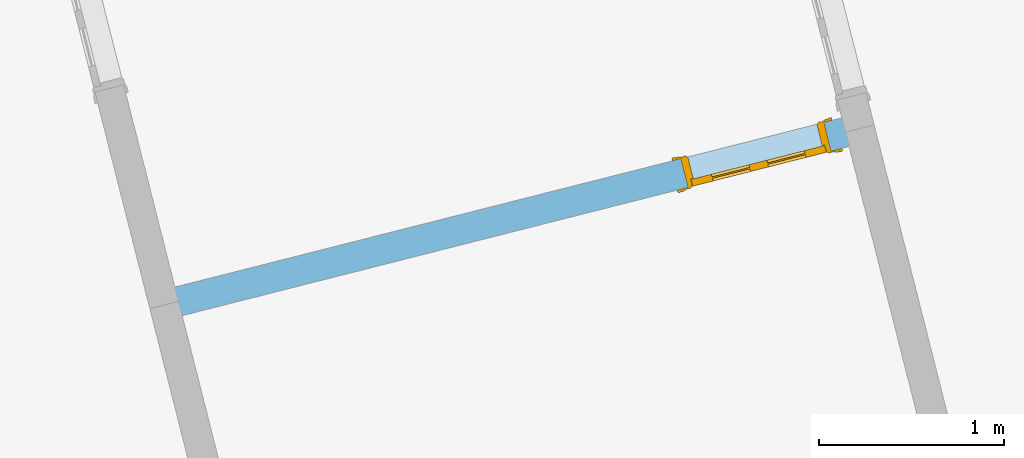
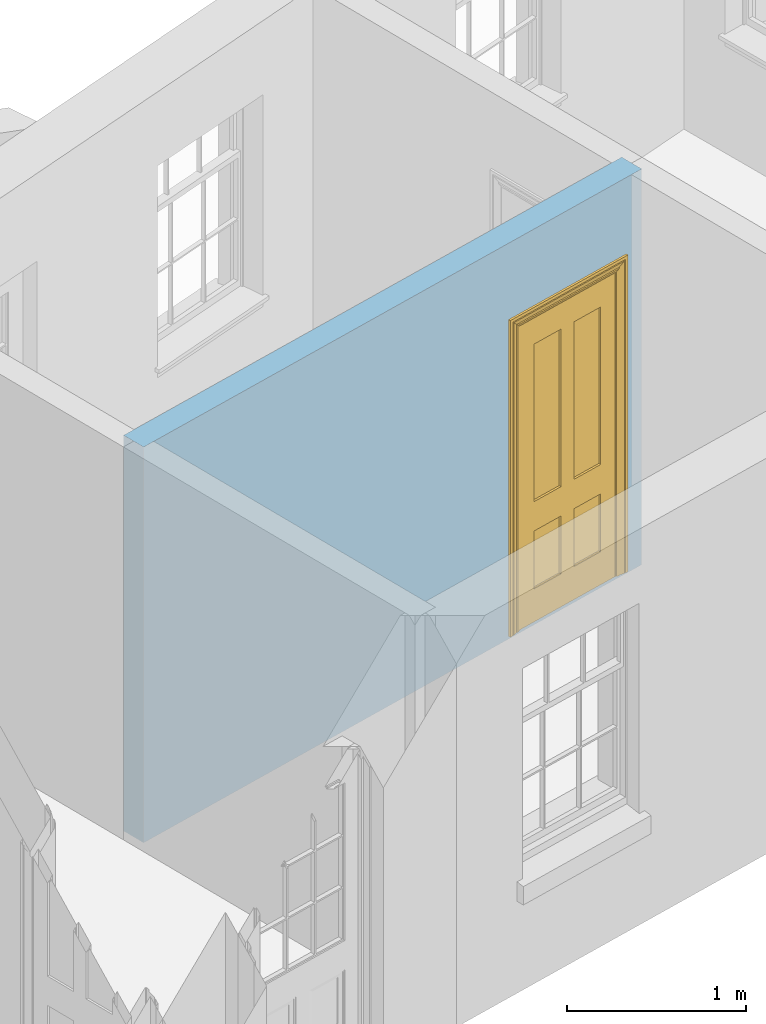
# One storey, part 8 of 15: 1 door, 1 opening, plus 1 element that does not belong to this part.
"""IFC2X3 building model written with IfcOpenShell, lengths in metres."""

from ifc_helpers import new_model, si_unit, frame, origin, place, context, subcontext, project, spatial, polyline, outline, extrude, faceted_brep, material, layer, layer_set, layer_usage, element, fill, save


model = new_model("IFC2X3")

# Units and contexts
model_context = context("Model", 3, world=origin())
body_context = subcontext(model_context, "Body", "Model", "MODEL_VIEW")
ifc_project = project(units=[si_unit("PLANEANGLEUNIT", "RADIAN"), si_unit("MASSUNIT", "GRAM", prefix="KILO"), si_unit("FORCEUNIT", "NEWTON", prefix="KILO"), si_unit("LENGTHUNIT", "METRE")], contexts=[model_context])

# Site, building, storey
site_placement = place(None, origin())
site = spatial("IfcSite", under=ifc_project, at=site_placement, CompositionType="ELEMENT")
building_placement = place(None, origin())
building = spatial("IfcBuilding", under=site, at=building_placement, Name="Building plot-13", CompositionType="ELEMENT")
storey_placement = place(None, frame((0.0, 0.0, 4.0)))
storey = spatial("IfcBuildingStorey", under=building, at=storey_placement, Name="Floor 0", CompositionType="ELEMENT", Elevation=4.0)

# Wall, opening, door
ifc_material = material(Name="Masonry")
ifc_layer = layer(ifc_material, 0.16, ventilated=False)
ifc_layer_set = layer_set([ifc_layer], Name="My Wall")
ifc_layer_usage = layer_usage(ifc_layer_set, "AXIS2", "NEGATIVE", 0.08)
wall_placement = place(storey_placement, origin())
wall = element("IfcWallStandardCase", 1, at=wall_placement, inside=storey, material=ifc_layer_usage, Name="interior", context=body_context, shape_type="SweptSolid", body=[
    extrude(outline(polyline([(76.3872594352377, 48.5815460629626), (76.3479245240301, 48.736635600844), (72.5821025731174, 47.7815210645155), (72.621437484325, 47.6264315266341), (76.3872594352377, 48.5815460629626)])), origin(), (0.0, 0.0, 1.0), 2.7),
])
opening_placement = place(storey_placement, frame((0.0, 0.0, 0.0199999999999996)))
opening = element("IfcOpeningElement", 2, at=opening_placement, cuts=wall, Name="Opening", ObjectType="Opening", context=body_context, shape_type="SweptSolid", body=[
    extrude(outline(polyline([(76.1734487939134, 48.6923838257354), (75.3980011045061, 48.495709269697), (75.4373360157138, 48.3406197318156), (76.2127837051211, 48.5372942878539), (76.1734487939134, 48.6923838257354)])), origin(), (0.0, 0.0, 1.0), 2.1),
])
door_placement = place(storey_placement, frame((76.1931162495173, 48.6148390567947, 0.0199999999999996), z_axis=(0.0, 0.0, 1.0), x_axis=(-0.775447689407301, -0.19667455603836, 0.0)))
door = element("IfcDoor", 3, at=door_placement, inside=storey, Name="toilet inside door", OverallHeight=2.1, OverallWidth=0.8, context=body_context, shape_type="Brep", held_by="IfcProductRepresentation", body=[
    faceted_brep([(0.773, 0.08, 1.895), (0.66, 0.08, 1.895), (0.66, 0.08, 2.073), (0.773, 0.08, 2.073), (0.773, 0.08, 0.82), (0.66, 0.08, 0.82), (0.45, 0.08, 1.895), (0.45, 0.08, 2.073), (0.773, 0.08, 0.62), (0.66, 0.08, 0.62), (0.66, 0.065, 0.82), (0.66, 0.065, 1.895), (0.45, 0.065, 1.895), (0.35, 0.08, 1.895), (0.35, 0.08, 2.073), (0.773, 0.08, 0.225), (0.66, 0.08, 0.225), (0.45, 0.08, 0.62), (0.45, 0.08, 0.82), (0.45, 0.065, 0.82), (0.35, 0.08, 0.82), (0.14, 0.08, 2.073), (0.14, 0.08, 1.895), (0.773, 0.08, 0.0), (0.66, 0.08, 0.0), (0.66, 0.065, 0.225), (0.66, 0.065, 0.62), (0.45, 0.065, 0.62), (0.35, 0.08, 0.62), (0.35, 0.065, 0.82), (0.35, 0.065, 1.895), (0.14, 0.065, 1.895), (0.027, 0.08, 2.073), (0.027, 0.08, 1.895), (0.773, 0.042, 0.0), (0.66, 0.042, 0.0), (0.45, 0.08, 0.0), (0.45, 0.08, 0.225), (0.45, 0.065, 0.225), (0.35, 0.08, 0.225), (0.14, 0.08, 0.82), (0.14, 0.08, 0.62), (0.14, 0.065, 0.82), (0.027, 0.08, 0.82), (0.773, 0.042, 0.225), (0.66, 0.042, 0.225), (0.45, 0.042, 0.0), (0.35, 0.08, 0.0), (0.35, 0.065, 0.225), (0.35, 0.065, 0.62), (0.14, 0.065, 0.62), (0.027, 0.08, 0.62), (0.773, 0.042, 0.62), (0.66, 0.042, 0.62), (0.45, 0.042, 0.225), (0.35, 0.042, 0.0), (0.14, 0.08, 0.225), (0.14, 0.08, 0.0), (0.14, 0.065, 0.225), (0.027, 0.08, 0.225), (0.773, 0.042, 0.82), (0.66, 0.042, 0.82), (0.66, 0.057, 0.62), (0.66, 0.057, 0.225), (0.45, 0.057, 0.225), (0.35, 0.042, 0.225), (0.14, 0.042, 0.0), (0.027, 0.08, 0.0), (0.773, 0.042, 1.895), (0.66, 0.042, 1.895), (0.45, 0.042, 0.62), (0.45, 0.042, 0.82), (0.45, 0.057, 0.62), (0.35, 0.042, 0.62), (0.14, 0.042, 0.225), (0.027, 0.042, 0.0), (0.773, 0.042, 2.073), (0.66, 0.042, 2.073), (0.66, 0.057, 1.895), (0.66, 0.057, 0.82), (0.45, 0.057, 0.82), (0.35, 0.042, 0.82), (0.35, 0.057, 0.62), (0.35, 0.057, 0.225), (0.14, 0.057, 0.225), (0.027, 0.042, 0.225), (0.45, 0.042, 1.895), (0.45, 0.042, 2.073), (0.45, 0.057, 1.895), (0.35, 0.042, 1.895), (0.14, 0.042, 0.82), (0.14, 0.042, 0.62), (0.14, 0.057, 0.62), (0.027, 0.042, 0.62), (0.35, 0.042, 2.073), (0.35, 0.057, 1.895), (0.35, 0.057, 0.82), (0.14, 0.057, 0.82), (0.027, 0.042, 0.82), (0.14, 0.042, 2.073), (0.14, 0.042, 1.895), (0.14, 0.057, 1.895), (0.027, 0.042, 1.895), (0.027, 0.042, 2.073), (0.02, 0.085, 0.0), (0.005, 0.09, 0.0), (0.005, 0.09, 2.095), (0.02, 0.085, 2.08), (0.02, 0.08, 0.0), (0.0, 0.085, 0.0), (0.0, 0.085, 2.1), (0.795, 0.09, 2.095), (0.78, 0.085, 2.08), (0.02, 0.08, 2.08), (0.0, 0.08, 0.0), (-0.032, 0.095, 0.0), (-0.032, 0.095, 2.132), (0.8, 0.085, 2.1), (0.795, 0.09, 0.0), (0.78, 0.085, 0.0), (0.78, 0.08, 2.08), (0.04, 0.04, 0.0), (0.025, 0.04, 0.0), (0.025, 0.04, 2.075), (0.04, 0.04, 2.06), (-0.04, 0.09, 0.0), (-0.04, 0.09, 2.14), (0.832, 0.095, 2.132), (0.8, 0.085, 0.0), (0.78, 0.08, 0.0), (0.8, 0.08, 0.0), (0.86, 0.08, 0.0), (0.86, 0.08, 2.16), (0.8, 0.08, 2.1), (-0.06, 0.08, 2.16), (0.0, 0.08, 2.1), (-0.06, 0.08, 0.0), (-0.04, 0.095, 0.0), (-0.04, 0.095, 2.14), (0.84, 0.09, 2.14), (0.832, 0.095, 0.0), (0.84, 0.09, 0.0), (0.86, 0.095, 0.0), (0.86, 0.095, 2.16), (-0.06, 0.095, 2.16), (-0.06, 0.095, 0.0), (0.84, 0.095, 0.0), (0.84, 0.095, 2.14), (-0.025, -0.095, 0.0), (-0.025, -0.09, 0.0), (-0.025, -0.09, 2.125), (-0.025, -0.095, 2.125), (-0.017, -0.095, 0.0), (-0.017, -0.095, 2.117), (0.825, -0.09, 2.125), (0.825, -0.095, 2.125), (0.825, -0.095, 0.0), (0.845, -0.095, 0.0), (-0.045, -0.095, 2.145), (-0.045, -0.095, 0.0), (0.845, -0.095, 2.145), (0.015, -0.085, 0.0), (0.015, -0.085, 2.085), (0.817, -0.095, 2.117), (0.825, -0.09, 0.0), (0.845, -0.08, 0.0), (0.845, -0.08, 2.145), (-0.045, -0.08, 2.145), (-0.045, -0.08, 0.0), (0.02, -0.09, 0.0), (0.02, -0.09, 2.08), (0.785, -0.085, 2.085), (0.817, -0.095, 0.0), (0.8, -0.08, 0.0), (0.8, -0.08, 2.1), (0.0, -0.08, 2.1), (0.0, -0.08, 0.0), (0.035, -0.085, 0.0), (0.035, -0.085, 2.065), (0.78, -0.09, 2.08), (0.785, -0.085, 0.0), (0.775, 0.04, 2.075), (0.76, 0.04, 2.06), (0.035, -0.08, 2.065), (0.035, -0.08, 0.0), (0.765, -0.085, 2.065), (0.78, -0.09, 0.0), (0.765, -0.08, 0.0), (0.765, -0.08, 2.065), (0.765, -0.085, 0.0), (0.04, -0.08, 2.06), (0.04, -0.08, 0.0), (0.76, -0.08, 2.06), (0.76, -0.08, 0.0), (0.76, 0.04, 0.0), (0.775, 0.04, 0.0), (0.025, 0.08, 0.0), (0.025, 0.08, 2.075), (0.775, 0.08, 0.0), (0.775, 0.08, 2.075)], [[[0, 1, 2, 3]], [[1, 0, 4, 5]], [[1, 6, 7, 2]], [[8, 9, 5, 4]], [[1, 5, 10, 11]], [[6, 1, 11, 12]], [[6, 13, 14, 7]], [[15, 16, 9, 8]], [[9, 17, 18, 5]], [[5, 18, 19, 10]], [[10, 19, 12, 11]], [[18, 6, 12, 19]], [[18, 20, 13, 6]], [[21, 14, 13, 22]], [[23, 24, 16, 15]], [[9, 16, 25, 26]], [[17, 9, 26, 27]], [[17, 28, 20, 18]], [[13, 20, 29, 30]], [[22, 13, 30, 31]], [[32, 21, 22, 33]], [[34, 35, 24, 23]], [[24, 36, 37, 16]], [[16, 37, 38, 25]], [[25, 38, 27, 26]], [[37, 17, 27, 38]], [[37, 39, 28, 17]], [[40, 20, 28, 41]], [[20, 40, 42, 29]], [[31, 30, 29, 42]], [[40, 22, 31, 42]], [[33, 22, 40, 43]], [[35, 34, 44, 45]], [[35, 46, 36, 24]], [[36, 47, 39, 37]], [[28, 39, 48, 49]], [[41, 28, 49, 50]], [[43, 40, 41, 51]], [[45, 44, 52, 53]], [[46, 35, 45, 54]], [[46, 55, 47, 36]], [[56, 39, 47, 57]], [[39, 56, 58, 48]], [[50, 49, 48, 58]], [[56, 41, 50, 58]], [[51, 41, 56, 59]], [[53, 52, 60, 61]], [[45, 53, 62, 63]], [[54, 45, 63, 64]], [[55, 46, 54, 65]], [[55, 66, 57, 47]], [[59, 56, 57, 67]], [[61, 60, 68, 69]], [[70, 53, 61, 71]], [[53, 70, 72, 62]], [[72, 64, 63, 62]], [[70, 54, 64, 72]], [[65, 54, 70, 73]], [[65, 74, 66, 55]], [[67, 57, 66, 75]], [[69, 68, 76, 77]], [[61, 69, 78, 79]], [[71, 61, 79, 80]], [[73, 70, 71, 81]], [[65, 73, 82, 83]], [[74, 65, 83, 84]], [[74, 85, 75, 66]], [[86, 69, 77, 87]], [[69, 86, 88, 78]], [[88, 80, 79, 78]], [[86, 71, 80, 88]], [[81, 71, 86, 89]], [[73, 81, 90, 91]], [[73, 91, 92, 82]], [[83, 82, 92, 84]], [[91, 74, 84, 92]], [[91, 93, 85, 74]], [[89, 86, 87, 94]], [[81, 89, 95, 96]], [[90, 81, 96, 97]], [[90, 98, 93, 91]], [[94, 99, 100, 89]], [[89, 100, 101, 95]], [[101, 97, 96, 95]], [[100, 90, 97, 101]], [[100, 102, 98, 90]], [[99, 103, 102, 100]], [[32, 103, 99, 21]], [[102, 103, 32, 33]], [[98, 102, 33, 43]], [[21, 99, 94, 14]], [[94, 87, 7, 14]], [[7, 87, 77, 2]], [[76, 3, 2, 77]], [[43, 51, 93, 98]], [[51, 59, 85, 93]], [[67, 75, 85, 59]], [[34, 23, 15, 44]], [[44, 15, 8, 52]], [[52, 8, 4, 60]], [[0, 68, 60, 4]], [[0, 3, 76, 68]], [[104, 105, 106, 107]], [[104, 108, 109, 105]], [[105, 109, 110, 106]], [[107, 106, 111, 112]], [[107, 113, 108, 104]], [[114, 109, 108]], [[109, 115, 116, 110]], [[106, 110, 117, 111]], [[112, 111, 118, 119]], [[113, 107, 112, 120]], [[121, 122, 123, 124]], [[115, 109, 114, 125]], [[115, 125, 126, 116]], [[110, 116, 127, 117]], [[111, 117, 128, 118]], [[118, 128, 129, 119]], [[120, 112, 119, 129]], [[130, 129, 128]], [[130, 131, 132, 133]], [[133, 132, 134, 135]], [[135, 134, 136, 114]], [[136, 125, 114]], [[125, 137, 138, 126]], [[116, 126, 139, 127]], [[117, 127, 140, 128]], [[141, 130, 128, 140]], [[131, 130, 141]], [[131, 142, 143, 132]], [[132, 143, 144, 134]], [[134, 144, 145, 136]], [[137, 125, 136, 145]], [[143, 142, 146]], [[143, 146, 147]], [[137, 145, 144]], [[143, 147, 138]], [[138, 137, 144]], [[143, 138, 144]], [[126, 138, 147, 139]], [[127, 139, 141, 140]], [[142, 131, 141, 146]], [[139, 147, 146, 141]], [[148, 149, 150, 151]], [[149, 152, 153, 150]], [[151, 150, 154, 155]], [[155, 156, 157]], [[158, 159, 148]], [[158, 148, 151]], [[155, 157, 160]], [[158, 151, 155]], [[155, 160, 158]], [[152, 161, 162, 153]], [[150, 153, 163, 154]], [[155, 154, 164, 156]], [[156, 164, 165, 157]], [[157, 165, 166, 160]], [[160, 166, 167, 158]], [[158, 167, 168, 159]], [[161, 169, 170, 162]], [[153, 162, 171, 163]], [[154, 163, 172, 164]], [[165, 164, 173]], [[165, 173, 174, 166]], [[166, 174, 175, 167]], [[167, 175, 176, 168]], [[169, 177, 178, 170]], [[162, 170, 179, 171]], [[163, 171, 180, 172]], [[172, 180, 173, 164]], [[124, 123, 181, 182]], [[183, 178, 177, 184]], [[170, 178, 185, 179]], [[171, 179, 186, 180]], [[187, 173, 180]], [[185, 188, 187, 189]], [[188, 185, 178, 183]], [[179, 185, 189, 186]], [[189, 187, 180, 186]], [[190, 183, 184, 191]], [[192, 188, 183, 190]], [[191, 184, 122, 121]], [[124, 190, 191, 121]], [[193, 187, 188, 192]], [[182, 192, 190, 124]], [[184, 176, 122]], [[194, 195, 187, 193]], [[192, 182, 194, 193]], [[161, 176, 184]], [[114, 108, 122, 176]], [[173, 187, 195]], [[152, 149, 176, 161]], [[169, 161, 184, 177]], [[196, 122, 108]], [[176, 175, 135, 114]], [[173, 195, 129, 130]], [[176, 149, 168]], [[123, 122, 196, 197]], [[196, 108, 113, 197]], [[175, 174, 133, 135]], [[198, 129, 195]], [[133, 174, 173, 130]], [[159, 168, 149, 148]], [[181, 123, 197, 199]], [[197, 113, 120, 199]], [[199, 120, 129, 198]], [[195, 181, 199, 198]], [[195, 194, 182, 181]]]),
])
fill(opening, door)

save(model, "model.ifc")
